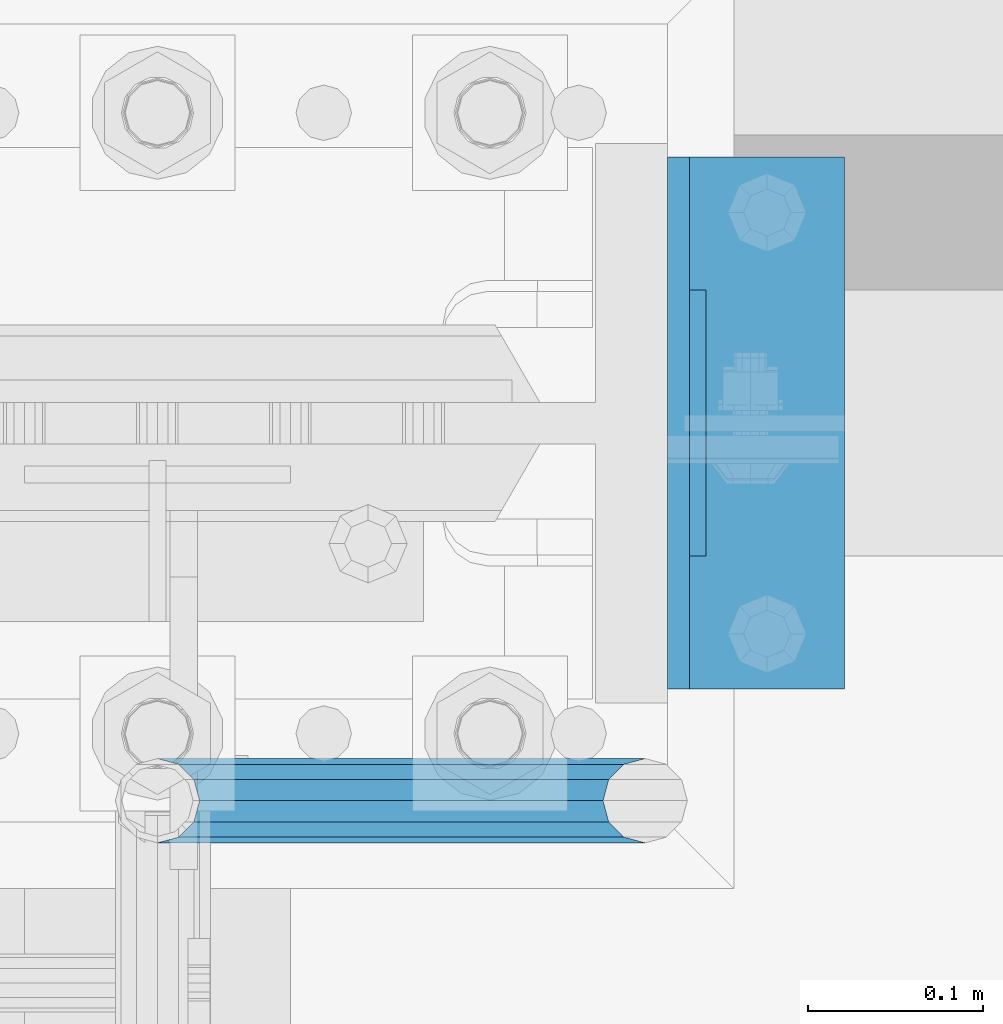
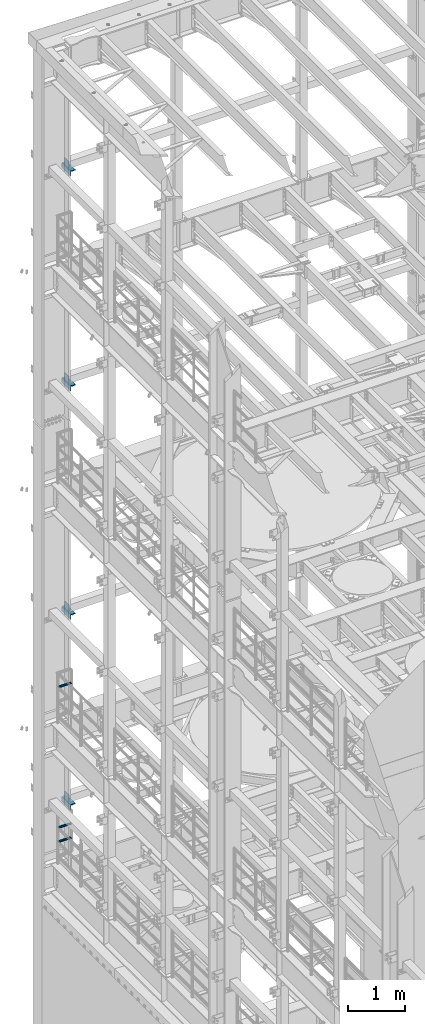
# One storey, part 1314 of 1876: 15 beams, 8 elements without a shape of their own.
"""IFC2X3 building model written with IfcOpenShell, lengths in millimetres."""

from ifc_helpers import new_model, si_unit, frame, origin_with_axes, place, context, subcontext, project, spatial, faceted_brep, material, type_object, element, aggregate, save


model = new_model("IFC2X3")

# Units and contexts
model_context = context("Model", 3, precision=1e-05, world=origin_with_axes())
body_context = subcontext(model_context, "Body", "Model", "MODEL_VIEW")
ifc_project = project(units=[si_unit("LENGTHUNIT", "METRE", prefix="MILLI"), si_unit("AREAUNIT", "SQUARE_METRE"), si_unit("VOLUMEUNIT", "CUBIC_METRE"), si_unit("MASSUNIT", "GRAM", prefix="KILO"), si_unit("TIMEUNIT", "SECOND"), si_unit("PLANEANGLEUNIT", "RADIAN"), si_unit("SOLIDANGLEUNIT", "STERADIAN"), si_unit("THERMODYNAMICTEMPERATUREUNIT", "DEGREE_CELSIUS"), si_unit("LUMINOUSINTENSITYUNIT", "LUMEN")], contexts=[model_context])

# Site, building, storey
site_placement = place(None, origin_with_axes())
site = spatial("IfcSite", under=ifc_project, at=site_placement, CompositionType="ELEMENT")
building_placement = place(site_placement, origin_with_axes())
building = spatial("IfcBuilding", under=site, at=building_placement, Name="Undefined", CompositionType="ELEMENT")
storey_placement = place(building_placement, origin_with_axes())
storey = spatial("IfcBuildingStorey", under=building, at=storey_placement, Name="Undefined", CompositionType="ELEMENT", Elevation=0.0)

# Assembly, beam
assembly_1_placement = place(storey_placement, origin_with_axes())
assembly_1 = element("IfcElementAssembly", 1, at=assembly_1_placement, inside=storey, Name="FRAME", AssemblyPlace="NOTDEFINED", PredefinedType="RIGID_FRAME")
ifc_material_1 = material(Name="STEEL/A36")
beam_type_1 = type_object("IfcBeamType", PredefinedType="NOTDEFINED")
beam_1_placement = place(assembly_1_placement, frame((309.5625, 13639.8, 6330.95), z_axis=(0.0, 0.0, 1.0), x_axis=(0.0, 1.0, 0.0)))
beam_1 = element("IfcBeam", 2, at=beam_1_placement, type_object=beam_type_1, material=ifc_material_1, Name="PLATE", context=body_context, shape_type="Brep", body=[
    faceted_brep([(0.0, 4.76249999999982, -76.1999999999998), (3.63797880709171e-12, 4.76249999999982, 76.1999969482422), (152.399993896484, 4.76250000000073, 76.1999969482422), (152.4, 4.76249999999982, -76.1999999999998), (3.63797880709171e-12, -4.76249999999982, 76.1999969482422), (152.399993896484, -4.76250000000073, 76.1999969482422), (0.0, -4.76249999999982, -76.1999999999998), (152.4, -4.76249999999982, -76.1999999999998)], [[[0, 1, 2, 3]], [[4, 5, 2, 1]], [[4, 6, 7, 5]], [[6, 0, 3, 7]], [[5, 7, 3, 2]], [[6, 4, 1, 0]]]),
])

assembly_2_placement = place(storey_placement, origin_with_axes())
assembly_2 = element("IfcElementAssembly", 3, at=assembly_2_placement, inside=storey, Name="FRAME", AssemblyPlace="NOTDEFINED", PredefinedType="RIGID_FRAME")
beam_2_placement = place(assembly_2_placement, frame((309.562499999999, 13639.8, 19958.05), z_axis=(0.0, 0.0, 1.0), x_axis=(0.0, 1.0, 0.0)))
beam_2 = element("IfcBeam", 4, at=beam_2_placement, type_object=beam_type_1, material=ifc_material_1, Name="PLATE", context=body_context, shape_type="Brep", body=[
    faceted_brep([(0.0, 4.76249999999982, -76.1999999999998), (3.63797880709171e-12, 4.76249999999982, 76.1999969482422), (152.399993896484, 4.76250000000073, 76.1999969482422), (152.4, 4.76249999999982, -76.1999999999998), (3.63797880709171e-12, -4.76249999999982, 76.1999969482422), (152.399993896484, -4.76250000000073, 76.1999969482422), (0.0, -4.76249999999982, -76.1999999999998), (152.4, -4.76249999999982, -76.1999999999998)], [[[0, 1, 2, 3]], [[4, 5, 2, 1]], [[4, 6, 7, 5]], [[6, 0, 3, 7]], [[5, 7, 3, 2]], [[6, 4, 1, 0]]]),
])

assembly_3_placement = place(storey_placement, origin_with_axes())
assembly_3 = element("IfcElementAssembly", 5, at=assembly_3_placement, inside=storey, Name="FRAME", AssemblyPlace="NOTDEFINED", PredefinedType="RIGID_FRAME")
beam_3_placement = place(assembly_3_placement, frame((309.5625, 13639.8, 15335.25), z_axis=(0.0, 0.0, 1.0), x_axis=(0.0, 1.0, 0.0)))
beam_3 = element("IfcBeam", 6, at=beam_3_placement, type_object=beam_type_1, material=ifc_material_1, Name="PLATE", context=body_context, shape_type="Brep", body=[
    faceted_brep([(0.0, 4.76249999999982, -76.1999999999998), (3.63797880709171e-12, 4.76249999999982, 76.1999969482422), (152.399993896484, 4.76250000000073, 76.1999969482422), (152.4, 4.76249999999982, -76.1999999999998), (3.63797880709171e-12, -4.76249999999982, 76.1999969482422), (152.399993896484, -4.76250000000073, 76.1999969482422), (0.0, -4.76249999999982, -76.1999999999998), (152.4, -4.76249999999982, -76.1999999999998)], [[[0, 1, 2, 3]], [[4, 5, 2, 1]], [[4, 6, 7, 5]], [[6, 0, 3, 7]], [[5, 7, 3, 2]], [[6, 4, 1, 0]]]),
])

assembly_4_placement = place(storey_placement, origin_with_axes())
assembly_4 = element("IfcElementAssembly", 7, at=assembly_4_placement, inside=storey, Name="FRAME", AssemblyPlace="NOTDEFINED", PredefinedType="RIGID_FRAME")
beam_4_placement = place(assembly_4_placement, frame((309.5625, 13639.8, 10420.35), z_axis=(0.0, 0.0, 1.0), x_axis=(0.0, 1.0, 0.0)))
beam_4 = element("IfcBeam", 8, at=beam_4_placement, type_object=beam_type_1, material=ifc_material_1, Name="PLATE", context=body_context, shape_type="Brep", body=[
    faceted_brep([(0.0, 4.76249999999982, -76.1999999999998), (3.63797880709171e-12, 4.76249999999982, 76.1999969482422), (152.399993896484, 4.76250000000073, 76.1999969482422), (152.4, 4.76249999999982, -76.1999999999998), (3.63797880709171e-12, -4.76249999999982, 76.1999969482422), (152.399993896484, -4.76250000000073, 76.1999969482422), (0.0, -4.76249999999982, -76.1999999999998), (152.4, -4.76249999999982, -76.1999999999998)], [[[0, 1, 2, 3]], [[4, 5, 2, 1]], [[4, 6, 7, 5]], [[6, 0, 3, 7]], [[5, 7, 3, 2]], [[6, 4, 1, 0]]]),
])

assembly_5_placement = place(storey_placement, origin_with_axes())
assembly_5 = element("IfcElementAssembly", 9, at=assembly_5_placement, inside=storey, Name="RAIL", AssemblyPlace="NOTDEFINED", PredefinedType="RIGID_FRAME")
ifc_material_2 = material()
beam_type_2 = type_object("IfcBeamType", Name="PIPE1-1/2SCH40", PredefinedType="NOTDEFINED")
beam_5_placement = place(assembly_5_placement, frame((-8.18545231595635e-12, 13499.7063, 8924.92500003594), z_axis=(0.0, 0.0, 1.0), x_axis=(1.0, 0.0, 0.0)))
beam_5 = element("IfcBeam", 10, at=beam_5_placement, type_object=beam_type_2, material=ifc_material_2, Name="RAIL", ObjectType="PIPE1-1/2SCH40", context=body_context, shape_type="Brep", body=[
    faceted_brep([(258.502800903171, -12.0650000000005, 20.8971929933177), (258.502800903171, -12.0650000000005, 15.8661214311796), (258.009372465309, -10.2235000000001, 17.7076214311819), (255.26999389649, 0.0, 20.4470000000001), (255.26999389649, 0.0, 24.130000000001), (258.009372465309, 10.2235000000001, 17.7076214311819), (258.502800903171, 12.0650000000005, 15.8661214311796), (258.502800903171, 12.0650000000005, 20.8971929933177), (279.399993896489, 24.1299999999992, 0.0), (267.33499389649, 20.8971929933177, 12.0649999999987), (267.33499389649, 20.8971929933177, -12.0649999999987), (264.145422334351, 17.7076214311801, 10.2235000000001), (266.884800903171, 20.4470000000001, 0.0), (264.145422334351, 17.7076214311801, -10.2235000000001), (258.502800903171, 12.0650000000005, -15.8661214311796), (258.502800903171, 12.0650000000005, -20.8971929933177), (258.009372465309, 10.2235000000001, -17.7076214311819), (255.26999389649, 0.0, -20.4470000000001), (255.26999389649, 0.0, -24.130000000001), (258.502800903171, -12.0650000000005, -15.8661214311796), (258.502800903171, -12.0650000000005, -20.8971929933177), (258.009372465309, -10.2235000000001, -17.7076214311819), (279.399993896489, -24.1299999999992, 0.0), (267.33499389649, -20.8971929933177, -12.0649999999987), (267.33499389649, -20.8971929933177, 12.0649999999987), (264.145422334351, -17.7076214311801, -10.2235000000001), (266.884800903171, -20.4470000000001, 0.0), (264.145422334351, -17.7076214311801, 10.2235000000001), (12.0650000000064, -20.8971929933177, -12.0649999999987), (20.8971929933249, -12.0650000000005, -20.8971929933177), (0.0, 24.1299999999992, 0.0), (12.0650000000064, 20.8971929933177, -12.0649999999987), (12.0650000000064, 20.8971929933177, 12.0649999999987), (20.8971929933249, 12.0650000000005, 20.8971929933177), (24.1300000000064, 0.0, 24.130000000001), (20.8971929933249, 12.0650000000005, -20.8971929933177), (24.1300000000063, 0.0, -24.130000000001), (24.1300000000063, 0.0, -20.4470000000001), (20.8971929933249, -12.0650000000005, -15.8661214311796), (21.3906214311868, -10.2235000000001, -17.7076214311819), (21.3906214311868, 10.2235000000001, -17.7076214311819), (20.8971929933249, 12.0650000000005, -15.8661214311796), (15.2545715621445, 17.7076214311801, -10.2235000000001), (12.5151929933249, 20.4470000000001, 0.0), (15.2545715621445, 17.7076214311801, 10.2235000000001), (20.8971929933249, 12.0650000000005, 15.8661214311796), (21.3906214311868, 10.2235000000001, 17.7076214311819), (24.1300000000064, 0.0, 20.4470000000001), (21.3906214311868, -10.2235000000001, 17.7076214311819), (20.8971929933249, -12.0650000000005, 15.8661214311796), (20.8971929933249, -12.0650000000005, 20.8971929933177), (12.0650000000064, -20.8971929933177, 12.0649999999987), (0.0, -24.1299999999992, 0.0), (15.2545715621445, -17.7076214311801, 10.2235000000001), (12.5151929933249, -20.4470000000001, 0.0), (15.2545715621445, -17.7076214311801, -10.2235000000001)], [[[0, 1, 2, 3, 4]], [[4, 3, 5, 6, 7]], [[8, 9, 10]], [[7, 6, 11, 12, 13, 14, 15, 10, 9]], [[16, 17, 18, 15, 14]], [[19, 20, 18, 17, 21]], [[22, 23, 24]], [[24, 23, 20, 19, 25, 26, 27, 1, 0]], [[28, 29, 20, 23]], [[30, 31, 32]], [[33, 34, 4, 7]], [[32, 33, 7, 9]], [[30, 32, 9, 8]], [[31, 30, 8, 10]], [[35, 31, 10, 15]], [[36, 35, 15, 18]], [[29, 36, 18, 20]], [[37, 36, 29, 38, 39]], [[40, 41, 35, 36, 37]], [[32, 31, 35, 41, 42, 43, 44, 45, 33]], [[33, 45, 46, 47, 34]], [[34, 47, 48, 49, 50]], [[34, 50, 0, 4]], [[50, 51, 24, 0]], [[51, 52, 22, 24]], [[52, 28, 23, 22]], [[51, 28, 52]], [[50, 49, 53, 54, 55, 38, 29, 28, 51]], [[55, 54, 26, 25]], [[21, 39, 38, 55, 25, 19]], [[37, 39, 21, 17]], [[40, 37, 17, 16]], [[42, 41, 40, 16, 14, 13]], [[43, 42, 13, 12]], [[44, 43, 12, 11]], [[5, 46, 45, 44, 11, 6]], [[47, 46, 5, 3]], [[48, 47, 3, 2]], [[53, 49, 48, 2, 1, 27]], [[54, 53, 27, 26]]]),
])
aggregate(assembly_5, [beam_5])

# Assembly, beams
assembly_6_placement = place(storey_placement, origin_with_axes())
assembly_6 = element("IfcElementAssembly", 11, at=assembly_6_placement, inside=storey, Name="RAIL", AssemblyPlace="NOTDEFINED", PredefinedType="RIGID_FRAME")
beam_6_placement = place(assembly_6_placement, frame((-8.18545231595635e-12, 13499.7063, 5597.525000036), z_axis=(0.0, 0.0, 1.0), x_axis=(1.0, 0.0, 0.0)))
beam_6 = element("IfcBeam", 12, at=beam_6_placement, type_object=beam_type_2, material=ifc_material_2, Name="RAIL", ObjectType="PIPE1-1/2SCH40", context=body_context, shape_type="Brep", body=[
    faceted_brep([(258.502800903171, -12.0650000000005, 20.8971929933177), (258.502800903171, -12.0650000000005, 15.8661214311796), (258.009372465309, -10.2235000000001, 17.7076214311819), (255.26999389649, 0.0, 20.4470000000001), (255.26999389649, 0.0, 24.130000000001), (258.009372465309, 10.2235000000001, 17.7076214311819), (258.502800903171, 12.0650000000005, 15.8661214311796), (258.502800903171, 12.0650000000005, 20.8971929933177), (279.399993896489, 24.1299999999992, 0.0), (267.33499389649, 20.8971929933177, 12.0649999999987), (267.33499389649, 20.8971929933177, -12.0649999999987), (264.145422334351, 17.7076214311801, 10.2235000000001), (266.884800903171, 20.4470000000001, 0.0), (264.145422334351, 17.7076214311801, -10.2235000000001), (258.502800903171, 12.0650000000005, -15.8661214311796), (258.502800903171, 12.0650000000005, -20.8971929933177), (258.009372465309, 10.2235000000001, -17.7076214311819), (255.26999389649, 0.0, -20.4470000000001), (255.26999389649, 0.0, -24.130000000001), (258.502800903171, -12.0650000000005, -15.8661214311796), (258.502800903171, -12.0650000000005, -20.8971929933177), (258.009372465309, -10.2235000000001, -17.7076214311819), (279.399993896489, -24.1299999999992, 0.0), (267.33499389649, -20.8971929933177, -12.0649999999987), (267.33499389649, -20.8971929933177, 12.0649999999987), (264.145422334351, -17.7076214311801, -10.2235000000001), (266.884800903171, -20.4470000000001, 0.0), (264.145422334351, -17.7076214311801, 10.2235000000001), (12.0650000000064, -20.8971929933177, -12.0649999999987), (20.8971929933249, -12.0650000000005, -20.8971929933177), (0.0, 24.1299999999992, 0.0), (12.0650000000064, 20.8971929933177, -12.0649999999987), (12.0650000000064, 20.8971929933177, 12.0649999999987), (20.8971929933249, 12.0650000000005, 20.8971929933177), (24.1300000000064, 0.0, 24.130000000001), (20.8971929933249, 12.0650000000005, -20.8971929933177), (24.1300000000063, 0.0, -24.130000000001), (24.1300000000063, 0.0, -20.4470000000001), (20.8971929933249, -12.0650000000005, -15.8661214311796), (21.3906214311868, -10.2235000000001, -17.7076214311819), (21.3906214311868, 10.2235000000001, -17.7076214311819), (20.8971929933249, 12.0650000000005, -15.8661214311796), (15.2545715621445, 17.7076214311801, -10.2235000000001), (12.5151929933249, 20.4470000000001, 0.0), (15.2545715621445, 17.7076214311801, 10.2235000000001), (20.8971929933249, 12.0650000000005, 15.8661214311796), (21.3906214311868, 10.2235000000001, 17.7076214311819), (24.1300000000064, 0.0, 20.4470000000001), (21.3906214311868, -10.2235000000001, 17.7076214311819), (20.8971929933249, -12.0650000000005, 15.8661214311796), (20.8971929933249, -12.0650000000005, 20.8971929933177), (12.0650000000064, -20.8971929933177, 12.0649999999987), (0.0, -24.1299999999992, 0.0), (15.2545715621445, -17.7076214311801, 10.2235000000001), (12.5151929933249, -20.4470000000001, 0.0), (15.2545715621445, -17.7076214311801, -10.2235000000001)], [[[0, 1, 2, 3, 4]], [[4, 3, 5, 6, 7]], [[8, 9, 10]], [[7, 6, 11, 12, 13, 14, 15, 10, 9]], [[16, 17, 18, 15, 14]], [[19, 20, 18, 17, 21]], [[22, 23, 24]], [[24, 23, 20, 19, 25, 26, 27, 1, 0]], [[28, 29, 20, 23]], [[30, 31, 32]], [[33, 34, 4, 7]], [[32, 33, 7, 9]], [[30, 32, 9, 8]], [[31, 30, 8, 10]], [[35, 31, 10, 15]], [[36, 35, 15, 18]], [[29, 36, 18, 20]], [[37, 36, 29, 38, 39]], [[40, 41, 35, 36, 37]], [[32, 31, 35, 41, 42, 43, 44, 45, 33]], [[33, 45, 46, 47, 34]], [[34, 47, 48, 49, 50]], [[34, 50, 0, 4]], [[50, 51, 24, 0]], [[51, 52, 22, 24]], [[52, 28, 23, 22]], [[51, 28, 52]], [[50, 49, 53, 54, 55, 38, 29, 28, 51]], [[55, 54, 26, 25]], [[21, 39, 38, 55, 25, 19]], [[37, 39, 21, 17]], [[40, 37, 17, 16]], [[42, 41, 40, 16, 14, 13]], [[43, 42, 13, 12]], [[44, 43, 12, 11]], [[5, 46, 45, 44, 11, 6]], [[47, 46, 5, 3]], [[48, 47, 3, 2]], [[53, 49, 48, 2, 1, 27]], [[54, 53, 27, 26]]]),
])
beam_7_placement = place(assembly_6_placement, frame((-8.18545231595635e-12, 13499.7063, 5902.32500003594), z_axis=(0.0, 0.0, 1.0), x_axis=(1.0, 0.0, 0.0)))
beam_7 = element("IfcBeam", 13, at=beam_7_placement, type_object=beam_type_2, material=ifc_material_2, Name="RAIL", ObjectType="PIPE1-1/2SCH40", context=body_context, shape_type="Brep", body=[
    faceted_brep([(258.502800903171, -12.0650000000005, 20.8971929933177), (258.502800903171, -12.0650000000005, 15.8661214311796), (258.009372465309, -10.2235000000001, 17.7076214311819), (255.26999389649, 0.0, 20.4470000000001), (255.26999389649, 0.0, 24.130000000001), (258.009372465309, 10.2235000000001, 17.7076214311819), (258.502800903171, 12.0650000000005, 15.8661214311796), (258.502800903171, 12.0650000000005, 20.8971929933177), (279.399993896489, 24.1299999999992, 0.0), (267.33499389649, 20.8971929933177, 12.0649999999987), (267.33499389649, 20.8971929933177, -12.0649999999987), (264.145422334351, 17.7076214311801, 10.2235000000001), (266.884800903171, 20.4470000000001, 0.0), (264.145422334351, 17.7076214311801, -10.2235000000001), (258.502800903171, 12.0650000000005, -15.8661214311796), (258.502800903171, 12.0650000000005, -20.8971929933177), (258.009372465309, 10.2235000000001, -17.7076214311819), (255.26999389649, 0.0, -20.4470000000001), (255.26999389649, 0.0, -24.130000000001), (258.502800903171, -12.0650000000005, -15.8661214311796), (258.502800903171, -12.0650000000005, -20.8971929933177), (258.009372465309, -10.2235000000001, -17.7076214311819), (279.399993896489, -24.1299999999992, 0.0), (267.33499389649, -20.8971929933177, -12.0649999999987), (267.33499389649, -20.8971929933177, 12.0649999999987), (264.145422334351, -17.7076214311801, -10.2235000000001), (266.884800903171, -20.4470000000001, 0.0), (264.145422334351, -17.7076214311801, 10.2235000000001), (12.0650000000064, -20.8971929933177, -12.0649999999987), (20.8971929933249, -12.0650000000005, -20.8971929933177), (0.0, 24.1299999999992, 0.0), (12.0650000000064, 20.8971929933177, -12.0649999999987), (12.0650000000064, 20.8971929933177, 12.0649999999987), (20.8971929933249, 12.0650000000005, 20.8971929933177), (24.1300000000064, 0.0, 24.130000000001), (20.8971929933249, 12.0650000000005, -20.8971929933177), (24.1300000000063, 0.0, -24.130000000001), (24.1300000000063, 0.0, -20.4470000000001), (20.8971929933249, -12.0650000000005, -15.8661214311796), (21.3906214311868, -10.2235000000001, -17.7076214311819), (21.3906214311868, 10.2235000000001, -17.7076214311819), (20.8971929933249, 12.0650000000005, -15.8661214311796), (15.2545715621445, 17.7076214311801, -10.2235000000001), (12.5151929933249, 20.4470000000001, 0.0), (15.2545715621445, 17.7076214311801, 10.2235000000001), (20.8971929933249, 12.0650000000005, 15.8661214311796), (21.3906214311868, 10.2235000000001, 17.7076214311819), (24.1300000000064, 0.0, 20.4470000000001), (21.3906214311868, -10.2235000000001, 17.7076214311819), (20.8971929933249, -12.0650000000005, 15.8661214311796), (20.8971929933249, -12.0650000000005, 20.8971929933177), (12.0650000000064, -20.8971929933177, 12.0649999999987), (0.0, -24.1299999999992, 0.0), (15.2545715621445, -17.7076214311801, 10.2235000000001), (12.5151929933249, -20.4470000000001, 0.0), (15.2545715621445, -17.7076214311801, -10.2235000000001)], [[[0, 1, 2, 3, 4]], [[4, 3, 5, 6, 7]], [[8, 9, 10]], [[7, 6, 11, 12, 13, 14, 15, 10, 9]], [[16, 17, 18, 15, 14]], [[19, 20, 18, 17, 21]], [[22, 23, 24]], [[24, 23, 20, 19, 25, 26, 27, 1, 0]], [[28, 29, 20, 23]], [[30, 31, 32]], [[33, 34, 4, 7]], [[32, 33, 7, 9]], [[30, 32, 9, 8]], [[31, 30, 8, 10]], [[35, 31, 10, 15]], [[36, 35, 15, 18]], [[29, 36, 18, 20]], [[37, 36, 29, 38, 39]], [[40, 41, 35, 36, 37]], [[32, 31, 35, 41, 42, 43, 44, 45, 33]], [[33, 45, 46, 47, 34]], [[34, 47, 48, 49, 50]], [[34, 50, 0, 4]], [[50, 51, 24, 0]], [[51, 52, 22, 24]], [[52, 28, 23, 22]], [[51, 28, 52]], [[50, 49, 53, 54, 55, 38, 29, 28, 51]], [[55, 54, 26, 25]], [[21, 39, 38, 55, 25, 19]], [[37, 39, 21, 17]], [[40, 37, 17, 16]], [[42, 41, 40, 16, 14, 13]], [[43, 42, 13, 12]], [[44, 43, 12, 11]], [[5, 46, 45, 44, 11, 6]], [[47, 46, 5, 3]], [[48, 47, 3, 2]], [[53, 49, 48, 2, 1, 27]], [[54, 53, 27, 26]]]),
])
aggregate(assembly_6, [beam_6, beam_7])

# Beam
beam_type_3 = type_object("IfcBeamType", PredefinedType="NOTDEFINED")
beam_8_placement = place(assembly_2_placement, frame((349.25, 13563.6, 19877.0875), z_axis=(1.0, 0.0, 0.0), x_axis=(0.0, 1.0, 0.0)))
beam_8 = element("IfcBeam", 14, at=beam_8_placement, type_object=beam_type_3, material=ifc_material_1, Name="PLATE", context=body_context, shape_type="Brep", body=[
    faceted_brep([(0.0, 4.76250000000073, -44.4499999999998), (0.0, 4.76250000000073, 44.4499999999998), (304.799999999999, 4.76250000000073, 44.4499999999998), (304.799999999999, 4.76250000000073, -44.4499999999998), (0.0, -4.76250000000073, 44.4499999999998), (304.799999999999, -4.76250000000073, 44.4499999999998), (0.0, -4.76250000000073, -44.4499999999998), (304.799999999999, -4.76250000000073, -44.4499999999998)], [[[0, 1, 2, 3]], [[1, 4, 5, 2]], [[4, 6, 7, 5]], [[6, 0, 3, 7]], [[5, 7, 3, 2]], [[6, 4, 1, 0]]]),
])

aggregate(assembly_2, [beam_8, beam_2])

beam_9_placement = place(assembly_3_placement, frame((349.25, 13563.6, 15254.2875), z_axis=(1.0, 0.0, 0.0), x_axis=(0.0, 1.0, 0.0)))
beam_9 = element("IfcBeam", 15, at=beam_9_placement, type_object=beam_type_3, material=ifc_material_1, Name="PLATE", context=body_context, shape_type="Brep", body=[
    faceted_brep([(0.0, 4.76250000000073, -44.4499999999998), (0.0, 4.76250000000073, 44.4499999999998), (304.799999999999, 4.76250000000073, 44.4499999999998), (304.799999999999, 4.76250000000073, -44.4499999999998), (0.0, -4.76250000000073, 44.4499999999998), (304.799999999999, -4.76250000000073, 44.4499999999998), (0.0, -4.76250000000073, -44.4499999999998), (304.799999999999, -4.76250000000073, -44.4499999999998)], [[[0, 1, 2, 3]], [[1, 4, 5, 2]], [[4, 6, 7, 5]], [[6, 0, 3, 7]], [[5, 7, 3, 2]], [[6, 4, 1, 0]]]),
])

aggregate(assembly_3, [beam_9, beam_3])

beam_10_placement = place(assembly_4_placement, frame((349.249999999907, 13563.6, 10339.3875), z_axis=(1.0, 0.0, 0.0), x_axis=(0.0, 1.0, 0.0)))
beam_10 = element("IfcBeam", 16, at=beam_10_placement, type_object=beam_type_3, material=ifc_material_1, Name="PLATE", context=body_context, shape_type="Brep", body=[
    faceted_brep([(0.0, 4.76250000000073, -44.4499999999998), (0.0, 4.76250000000073, 44.4499999999998), (304.799999999999, 4.76250000000073, 44.4499999999998), (304.799999999999, 4.76250000000073, -44.4499999999998), (0.0, -4.76250000000073, 44.4499999999998), (304.799999999999, -4.76250000000073, 44.4499999999998), (0.0, -4.76250000000073, -44.4499999999998), (304.799999999999, -4.76250000000073, -44.4499999999998)], [[[0, 1, 2, 3]], [[1, 4, 5, 2]], [[4, 6, 7, 5]], [[6, 0, 3, 7]], [[5, 7, 3, 2]], [[6, 4, 1, 0]]]),
])

aggregate(assembly_4, [beam_10, beam_4])

beam_11_placement = place(assembly_1_placement, frame((349.25, 13563.6, 6249.9875), z_axis=(1.0, 0.0, 0.0), x_axis=(0.0, 1.0, 0.0)))
beam_11 = element("IfcBeam", 17, at=beam_11_placement, type_object=beam_type_3, material=ifc_material_1, Name="PLATE", context=body_context, shape_type="Brep", body=[
    faceted_brep([(0.0, 4.76250000000073, -44.4499999999998), (0.0, 4.76250000000073, 44.4499999999998), (304.799999999999, 4.76250000000073, 44.4499999999998), (304.799999999999, 4.76250000000073, -44.4499999999998), (0.0, -4.76250000000073, 44.4499999999998), (304.799999999999, -4.76250000000073, 44.4499999999998), (0.0, -4.76250000000073, -44.4499999999998), (304.799999999999, -4.76250000000073, -44.4499999999998)], [[[0, 1, 2, 3]], [[1, 4, 5, 2]], [[4, 6, 7, 5]], [[6, 0, 3, 7]], [[5, 7, 3, 2]], [[6, 4, 1, 0]]]),
])

aggregate(assembly_1, [beam_11, beam_1])

# Assembly, beams
assembly_7_placement = place(storey_placement, origin_with_axes())
assembly_7 = element("IfcElementAssembly", 18, at=assembly_7_placement, inside=storey, Name="COLUMN", AssemblyPlace="NOTDEFINED", PredefinedType="RIGID_FRAME")
beam_type_4 = type_object("IfcBeamType", Name="L4X4X3/8", PredefinedType="NOTDEFINED")
beam_12_placement = place(assembly_7_placement, frame((342.9, 13563.6, 19821.525), z_axis=(1.0, 0.0, 0.0), x_axis=(0.0, 1.0, 0.0)))
beam_12 = element("IfcBeam", 19, at=beam_12_placement, type_object=beam_type_4, material=ifc_material_1, Name="ANGLE", ObjectType="L4X4X3/8", context=body_context, shape_type="Brep", body=[
    faceted_brep([(0.0, 50.7999999999993, -50.8000000000002), (0.0, 50.7999999999993, 50.8000000000002), (304.799999999999, 50.7999999999993, 50.8000000000002), (304.799999999999, 50.7999999999993, -50.8000000000002), (0.0, 41.2750000000015, 50.8000000000002), (304.799999999999, 41.2750000000015, 50.8000000000002), (0.0, 41.2750000000015, -41.2749999999996), (304.799999999999, 41.2750000000015, -41.2749999999996), (0.0, -50.7999999999993, -41.2749999999996), (304.799999999999, -50.7999999999993, -41.2749999999996), (0.0, -50.7999999999993, -50.8000000000002), (304.799999999999, -50.7999999999993, -50.8000000000002)], [[[0, 1, 2, 3]], [[1, 4, 5, 2]], [[4, 6, 7, 5]], [[6, 8, 9, 7]], [[8, 10, 11, 9]], [[10, 0, 3, 11]], [[5, 7, 9, 11, 3, 2]], [[10, 8, 6, 4, 1, 0]]]),
])
beam_13_placement = place(assembly_7_placement, frame((342.9, 13563.6, 15198.725), z_axis=(1.0, 0.0, 0.0), x_axis=(0.0, 1.0, 0.0)))
beam_13 = element("IfcBeam", 20, at=beam_13_placement, type_object=beam_type_4, material=ifc_material_1, Name="ANGLE", ObjectType="L4X4X3/8", context=body_context, shape_type="Brep", body=[
    faceted_brep([(0.0, 50.7999999999993, -50.8000000000002), (0.0, 50.7999999999993, 50.8000000000002), (304.799999999999, 50.7999999999993, 50.8000000000002), (304.799999999999, 50.7999999999993, -50.8000000000002), (0.0, 41.2750000000015, 50.8000000000002), (304.799999999999, 41.2750000000015, 50.8000000000002), (0.0, 41.2750000000015, -41.2749999999996), (304.799999999999, 41.2750000000015, -41.2749999999996), (0.0, -50.7999999999993, -41.2749999999996), (304.799999999999, -50.7999999999993, -41.2749999999996), (0.0, -50.7999999999993, -50.8000000000002), (304.799999999999, -50.7999999999993, -50.8000000000002)], [[[0, 1, 2, 3]], [[1, 4, 5, 2]], [[4, 6, 7, 5]], [[6, 8, 9, 7]], [[8, 10, 11, 9]], [[10, 0, 3, 11]], [[5, 7, 9, 11, 3, 2]], [[10, 8, 6, 4, 1, 0]]]),
])
aggregate(assembly_7, [beam_12, beam_13])

assembly_8_placement = place(storey_placement, origin_with_axes())
assembly_8 = element("IfcElementAssembly", 21, at=assembly_8_placement, inside=storey, Name="COLUMN", AssemblyPlace="NOTDEFINED", PredefinedType="RIGID_FRAME")
beam_14_placement = place(assembly_8_placement, frame((342.899999999905, 13563.6, 10283.825), z_axis=(1.0, 0.0, 0.0), x_axis=(0.0, 1.0, 0.0)))
beam_14 = element("IfcBeam", 22, at=beam_14_placement, type_object=beam_type_4, material=ifc_material_1, Name="ANGLE", ObjectType="L4X4X3/8", context=body_context, shape_type="Brep", body=[
    faceted_brep([(0.0, 50.7999999999993, -50.8000000000002), (0.0, 50.7999999999993, 50.8000000000002), (304.799999999999, 50.7999999999993, 50.8000000000002), (304.799999999999, 50.7999999999993, -50.8000000000002), (0.0, 41.2750000000015, 50.8000000000002), (304.799999999999, 41.2750000000015, 50.8000000000002), (0.0, 41.2750000000015, -41.2749999999996), (304.799999999999, 41.2750000000015, -41.2749999999996), (0.0, -50.7999999999993, -41.2749999999996), (304.799999999999, -50.7999999999993, -41.2749999999996), (0.0, -50.7999999999993, -50.8000000000002), (304.799999999999, -50.7999999999993, -50.8000000000002)], [[[0, 1, 2, 3]], [[1, 4, 5, 2]], [[4, 6, 7, 5]], [[6, 8, 9, 7]], [[8, 10, 11, 9]], [[10, 0, 3, 11]], [[5, 7, 9, 11, 3, 2]], [[10, 8, 6, 4, 1, 0]]]),
])
beam_15_placement = place(assembly_8_placement, frame((342.9, 13563.6, 6194.425), z_axis=(1.0, 0.0, 0.0), x_axis=(0.0, 1.0, 0.0)))
beam_15 = element("IfcBeam", 23, at=beam_15_placement, type_object=beam_type_4, material=ifc_material_1, Name="ANGLE", ObjectType="L4X4X3/8", context=body_context, shape_type="Brep", body=[
    faceted_brep([(0.0, 50.7999999999993, -50.8000000000002), (0.0, 50.7999999999993, 50.8000000000002), (304.799999999999, 50.7999999999993, 50.8000000000002), (304.799999999999, 50.7999999999993, -50.8000000000002), (0.0, 41.2750000000015, 50.8000000000002), (304.799999999999, 41.2750000000015, 50.8000000000002), (0.0, 41.2750000000015, -41.2749999999996), (304.799999999999, 41.2750000000015, -41.2749999999996), (0.0, -50.7999999999993, -41.2749999999996), (304.799999999999, -50.7999999999993, -41.2749999999996), (0.0, -50.7999999999993, -50.8000000000002), (304.799999999999, -50.7999999999993, -50.8000000000002)], [[[0, 1, 2, 3]], [[1, 4, 5, 2]], [[4, 6, 7, 5]], [[6, 8, 9, 7]], [[8, 10, 11, 9]], [[10, 0, 3, 11]], [[5, 7, 9, 11, 3, 2]], [[10, 8, 6, 4, 1, 0]]]),
])
aggregate(assembly_8, [beam_14, beam_15])

save(model, "model.ifc")
